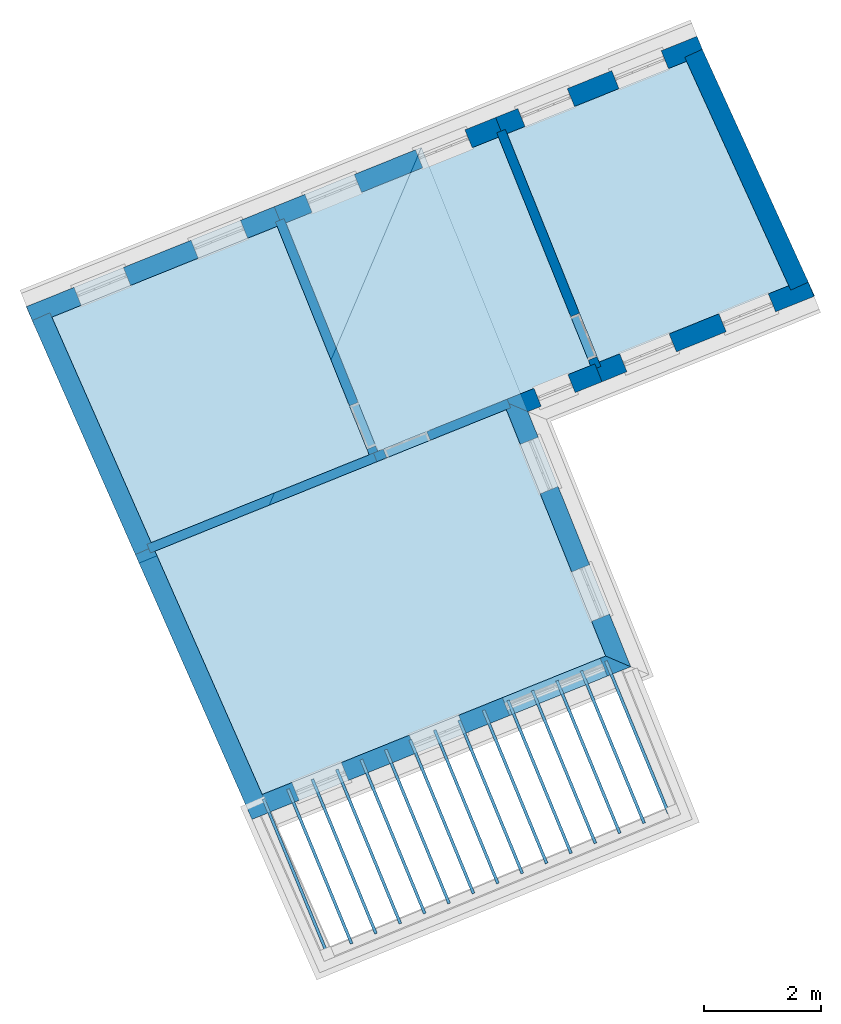
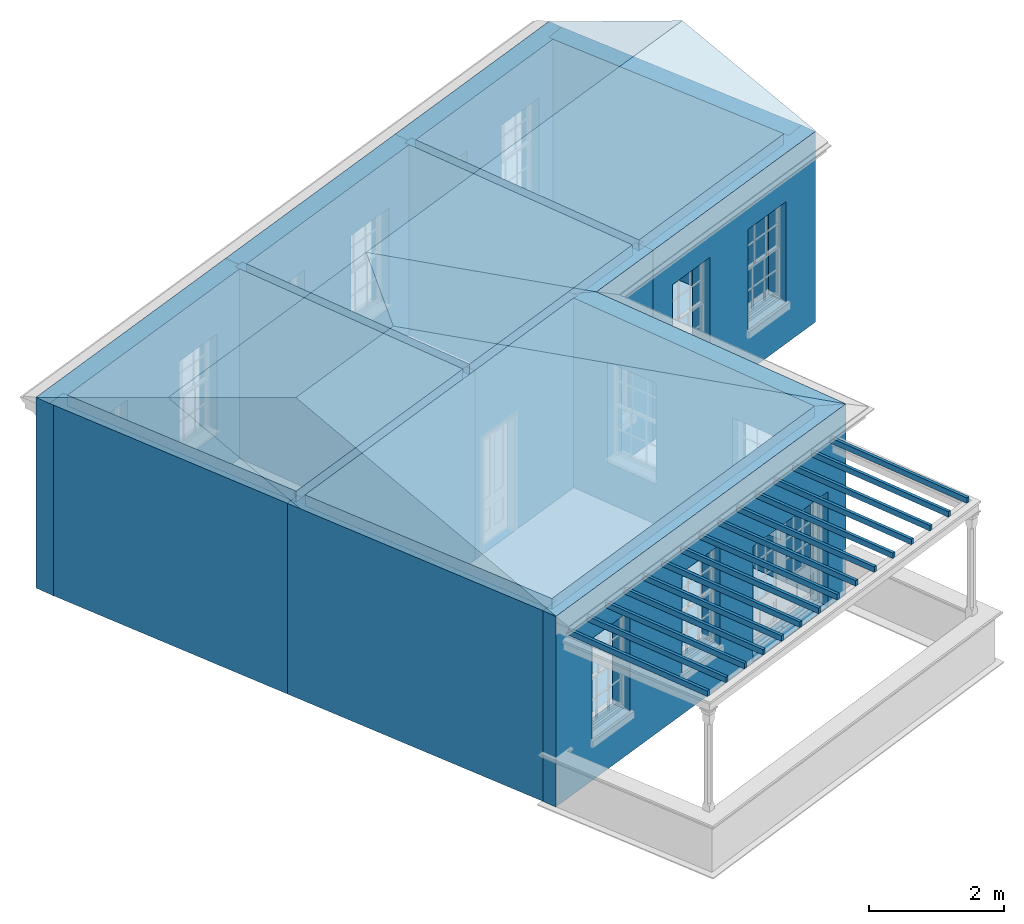
# One storey, part 1 of 11: 22 slabs, 14 walls, 2 roofs, 17 openings.
"""IFC2X3 building model written with IfcOpenShell, lengths in metres."""

from ifc_helpers import new_model, si_unit, frame, origin, place, context, subcontext, project, spatial, polyline, outline, extrude, faceted_brep, material, layer, layer_set, layer_usage, element, save


model = new_model("IFC2X3")

# Units and contexts
model_context = context("Model", 3, world=origin())
body_context = subcontext(model_context, "Body", "Model", "MODEL_VIEW")
ifc_project = project(units=[si_unit("PLANEANGLEUNIT", "RADIAN"), si_unit("MASSUNIT", "GRAM", prefix="KILO"), si_unit("FORCEUNIT", "NEWTON", prefix="KILO"), si_unit("LENGTHUNIT", "METRE")], contexts=[model_context])

# Site, building, storey
site_placement = place(None, origin())
site = spatial("IfcSite", under=ifc_project, at=site_placement, CompositionType="ELEMENT")
building_placement = place(None, origin())
building = spatial("IfcBuilding", under=site, at=building_placement, Name="Building plot-6", CompositionType="ELEMENT")
storey_placement = place(None, frame((0.0, 0.0, 7.6)))
storey = spatial("IfcBuildingStorey", under=building, at=storey_placement, Name="Floor 1", CompositionType="ELEMENT", Elevation=7.6)

# Slabs
slab_1_placement = place(storey_placement, frame((0.0, 0.0, 3.25)))
element("IfcSlab", 1, at=slab_1_placement, inside=storey, Name="Slab", ObjectType="Slab", PredefinedType="FLOOR", context=body_context, shape_type="SweptSolid", body=[
    extrude(outline(polyline([(76.2577457902025, 64.6686020443732), (74.5135630710952, 68.4972584544611), (71.4513008288675, 67.2630875650073), (73.0224536163486, 63.3646956170308), (76.2577457902025, 64.6686020443732)])), origin(), (0.0, 0.0, 1.0), 0.2),
])
slab_2_placement = place(storey_placement, frame((0.0, 0.0, 3.25)))
element("IfcSlab", 2, at=slab_2_placement, inside=storey, Name="Slab", ObjectType="Slab", PredefinedType="FLOOR", context=body_context, shape_type="SweptSolid", body=[
    extrude(outline(polyline([(63.6804234192607, 64.1312229741175), (65.3761845528931, 60.2830514126522), (69.0963028168147, 61.7823552943856), (67.5251500293337, 65.6807472423621), (63.6804234192607, 64.1312229741175)])), origin(), (0.0, 0.0, 1.0), 0.2),
])
slab_3_placement = place(storey_placement, frame((0.0, 0.0, 3.25)))
element("IfcSlab", 3, at=slab_3_placement, inside=storey, Name="Slab", ObjectType="Slab", PredefinedType="FLOOR", context=body_context, shape_type="SweptSolid", body=[
    extrude(outline(polyline([(65.440737456539, 60.1365622385029), (67.2704046682872, 55.9845191284493), (73.1321758860389, 58.3469645447258), (71.4369567405552, 62.553193703002), (65.440737456539, 60.1365622385029)])), origin(), (0.0, 0.0, 1.0), 0.2),
])
slab_4_placement = place(storey_placement, frame((0.0, 0.0, 2.95)))
element("IfcSlab", 4, at=slab_4_placement, inside=storey, Name="Slab", ObjectType="Slab", PredefinedType="FLOOR", context=body_context, shape_type="SweptSolid", body=[
    extrude(outline(polyline([(68.3583884275437, 53.2552034661946), (68.4046173515025, 53.2742530485946), (67.3157256834263, 55.9167409029541), (67.2694967594675, 55.897691320554), (68.3583884275437, 53.2552034661946)])), origin(), (0.0, 0.0, 1.0), 0.1),
])
slab_5_placement = place(storey_placement, frame((0.0, 0.0, 2.95)))
element("IfcSlab", 5, at=slab_5_placement, inside=storey, Name="Slab", ObjectType="Slab", PredefinedType="FLOOR", context=body_context, shape_type="SweptSolid", body=[
    extrude(outline(polyline([(68.7744487431724, 53.4266497077952), (68.8206776671311, 53.4456992901953), (67.7331158388372, 56.0849599314387), (67.6868869148785, 56.0659103490387), (68.7744487431724, 53.4266497077952)])), origin(), (0.0, 0.0, 1.0), 0.1),
])
slab_6_placement = place(storey_placement, frame((0.0, 0.0, 2.95)))
element("IfcSlab", 6, at=slab_6_placement, inside=storey, Name="Slab", ObjectType="Slab", PredefinedType="FLOOR", context=body_context, shape_type="SweptSolid", body=[
    extrude(outline(polyline([(69.190509058801, 53.5980959493958), (69.2367379827598, 53.6171455317959), (68.1505059942482, 56.2531789599234), (68.1042770702895, 56.2341293775233), (69.190509058801, 53.5980959493958)])), origin(), (0.0, 0.0, 1.0), 0.1),
])
slab_7_placement = place(storey_placement, frame((0.0, 0.0, 2.95)))
element("IfcSlab", 7, at=slab_7_placement, inside=storey, Name="Slab", ObjectType="Slab", PredefinedType="FLOOR", context=body_context, shape_type="SweptSolid", body=[
    extrude(outline(polyline([(69.6065693744297, 53.7695421909965), (69.6527982983884, 53.7885917733965), (68.5678961496592, 56.4213979884081), (68.5216672257005, 56.402348406008), (69.6065693744297, 53.7695421909965)])), origin(), (0.0, 0.0, 1.0), 0.1),
])
slab_8_placement = place(storey_placement, frame((0.0, 0.0, 2.95)))
element("IfcSlab", 8, at=slab_8_placement, inside=storey, Name="Slab", ObjectType="Slab", PredefinedType="FLOOR", context=body_context, shape_type="SweptSolid", body=[
    extrude(outline(polyline([(70.0226296900584, 53.9409884325971), (70.0688586140171, 53.9600380149972), (68.9852863050702, 56.5896170168928), (68.9390573811115, 56.5705674344927), (70.0226296900584, 53.9409884325971)])), origin(), (0.0, 0.0, 1.0), 0.1),
])
slab_9_placement = place(storey_placement, frame((0.0, 0.0, 2.95)))
element("IfcSlab", 9, at=slab_9_placement, inside=storey, Name="Slab", ObjectType="Slab", PredefinedType="FLOOR", context=body_context, shape_type="SweptSolid", body=[
    extrude(outline(polyline([(70.438690005687, 54.1124346741977), (70.4849189296458, 54.1314842565978), (69.4026764604812, 56.7578360453775), (69.3564475365225, 56.7387864629774), (70.438690005687, 54.1124346741977)])), origin(), (0.0, 0.0, 1.0), 0.1),
])
slab_10_placement = place(storey_placement, frame((0.0, 0.0, 2.95)))
element("IfcSlab", 10, at=slab_10_placement, inside=storey, Name="Slab", ObjectType="Slab", PredefinedType="FLOOR", context=body_context, shape_type="SweptSolid", body=[
    extrude(outline(polyline([(70.8547503213157, 54.2838809157983), (70.9009792452744, 54.3029304981984), (69.8200666158922, 56.9260550738621), (69.7738376919335, 56.9070054914621), (70.8547503213157, 54.2838809157983)])), origin(), (0.0, 0.0, 1.0), 0.1),
])
slab_11_placement = place(storey_placement, frame((0.0, 0.0, 2.95)))
element("IfcSlab", 11, at=slab_11_placement, inside=storey, Name="Slab", ObjectType="Slab", PredefinedType="FLOOR", context=body_context, shape_type="SweptSolid", body=[
    extrude(outline(polyline([(71.2708106369443, 54.455327157399), (71.3170395609031, 54.474376739799), (70.2374567713032, 57.0942741023468), (70.1912278473444, 57.0752245199468), (71.2708106369443, 54.455327157399)])), origin(), (0.0, 0.0, 1.0), 0.1),
])
slab_12_placement = place(storey_placement, frame((0.0, 0.0, 2.95)))
element("IfcSlab", 12, at=slab_12_placement, inside=storey, Name="Slab", ObjectType="Slab", PredefinedType="FLOOR", context=body_context, shape_type="SweptSolid", body=[
    extrude(outline(polyline([(71.686870952573, 54.6267733989996), (71.7330998765318, 54.6458229813997), (70.6548469267142, 57.2624931308315), (70.6086180027554, 57.2434435484314), (71.686870952573, 54.6267733989996)])), origin(), (0.0, 0.0, 1.0), 0.1),
])
slab_13_placement = place(storey_placement, frame((0.0, 0.0, 2.95)))
element("IfcSlab", 13, at=slab_13_placement, inside=storey, Name="Slab", ObjectType="Slab", PredefinedType="FLOOR", context=body_context, shape_type="SweptSolid", body=[
    extrude(outline(polyline([(72.1029312682017, 54.7982196406002), (72.1491601921604, 54.8172692230003), (71.0722370821252, 57.4307121593162), (71.0260081581664, 57.4116625769161), (72.1029312682017, 54.7982196406002)])), origin(), (0.0, 0.0, 1.0), 0.1),
])
slab_14_placement = place(storey_placement, frame((0.0, 0.0, 2.95)))
element("IfcSlab", 14, at=slab_14_placement, inside=storey, Name="Slab", ObjectType="Slab", PredefinedType="FLOOR", context=body_context, shape_type="SweptSolid", body=[
    extrude(outline(polyline([(72.5189915838303, 54.9696658822008), (72.5652205077891, 54.9887154646009), (71.4896272375362, 57.5989311878009), (71.4433983135774, 57.5798816054008), (72.5189915838303, 54.9696658822008)])), origin(), (0.0, 0.0, 1.0), 0.1),
])
slab_15_placement = place(storey_placement, frame((0.0, 0.0, 2.95)))
element("IfcSlab", 15, at=slab_15_placement, inside=storey, Name="Slab", ObjectType="Slab", PredefinedType="FLOOR", context=body_context, shape_type="SweptSolid", body=[
    extrude(outline(polyline([(72.935051899459, 55.1411121238014), (72.9812808234177, 55.1601617062015), (71.9070173929472, 57.7671502162856), (71.8607884689884, 57.7481006338855), (72.935051899459, 55.1411121238014)])), origin(), (0.0, 0.0, 1.0), 0.1),
])
slab_16_placement = place(storey_placement, frame((0.0, 0.0, 2.95)))
element("IfcSlab", 16, at=slab_16_placement, inside=storey, Name="Slab", ObjectType="Slab", PredefinedType="FLOOR", context=body_context, shape_type="SweptSolid", body=[
    extrude(outline(polyline([(73.3511122150876, 55.3125583654021), (73.3973411390464, 55.3316079478022), (72.3244075483582, 57.9353692447702), (72.2781786243994, 57.9163196623702), (73.3511122150876, 55.3125583654021)])), origin(), (0.0, 0.0, 1.0), 0.1),
])
slab_17_placement = place(storey_placement, frame((0.0, 0.0, 2.95)))
element("IfcSlab", 17, at=slab_17_placement, inside=storey, Name="Slab", ObjectType="Slab", PredefinedType="FLOOR", context=body_context, shape_type="SweptSolid", body=[
    extrude(outline(polyline([(73.7671725307163, 55.4840046070027), (73.8134014546751, 55.5030541894028), (72.7417977037691, 58.1035882732549), (72.6955687798104, 58.0845386908549), (73.7671725307163, 55.4840046070027)])), origin(), (0.0, 0.0, 1.0), 0.1),
])
slab_18_placement = place(storey_placement, frame((0.0, 0.0, 2.95)))
element("IfcSlab", 18, at=slab_18_placement, inside=storey, Name="Slab", ObjectType="Slab", PredefinedType="FLOOR", context=body_context, shape_type="SweptSolid", body=[
    extrude(outline(polyline([(74.183232846345, 55.6554508486033), (74.2294617703037, 55.6745004310034), (73.1591878591801, 58.2718073017396), (73.1129589352214, 58.2527577193395), (74.183232846345, 55.6554508486033)])), origin(), (0.0, 0.0, 1.0), 0.1),
])
slab_19_placement = place(storey_placement, frame((0.0, 0.0, 3.25)))
element("IfcSlab", 19, at=slab_19_placement, inside=storey, Name="Slab", ObjectType="Slab", PredefinedType="FLOOR", context=body_context, shape_type="SweptSolid", body=[
    extrude(outline(polyline([(69.2447037412141, 61.842164705329), (72.8740526919492, 63.3048862060874), (71.3028999044681, 67.2032781540639), (67.6735509537331, 65.7405566533055), (69.2447037412141, 61.842164705329)])), origin(), (0.0, 0.0, 1.0), 0.2),
])
slab_20_placement = place(storey_placement, origin())
element("IfcSlab", 20, at=slab_20_placement, inside=storey, Name="Slab", ObjectType="Slab", PredefinedType="FLOOR", context=body_context, shape_type="SweptSolid", body=[
    extrude(outline(polyline([(76.2577457902025, 64.6686020443732), (74.5135630710952, 68.4972584544611), (71.4513008288675, 67.2630875650073), (73.0224536163486, 63.3646956170308), (76.2577457902025, 64.6686020443732)])), origin(), (0.0, 0.0, 1.0), 0.02),
])
slab_21_placement = place(storey_placement, origin())
element("IfcSlab", 21, at=slab_21_placement, inside=storey, Name="Slab", ObjectType="Slab", PredefinedType="FLOOR", context=body_context, shape_type="SweptSolid", body=[
    extrude(outline(polyline([(63.6804234192607, 64.1312229741175), (65.3761845528931, 60.2830514126522), (69.0963028168147, 61.7823552943856), (67.5251500293337, 65.6807472423621), (63.6804234192607, 64.1312229741175)])), origin(), (0.0, 0.0, 1.0), 0.02),
])
slab_22_placement = place(storey_placement, origin())
element("IfcSlab", 22, at=slab_22_placement, inside=storey, Name="Slab", ObjectType="Slab", PredefinedType="FLOOR", context=body_context, shape_type="SweptSolid", body=[
    extrude(outline(polyline([(65.440737456539, 60.1365622385029), (67.2704046682872, 55.9845191284493), (73.1321758860389, 58.3469645447258), (71.4369567405552, 62.553193703002), (65.440737456539, 60.1365622385029)])), origin(), (0.0, 0.0, 1.0), 0.02),
])

# Wall, openings
ifc_material_1 = material(Name="Masonry")
ifc_layer_1 = layer(ifc_material_1, 0.33, ventilated=False)
ifc_layer_set_1 = layer_set([ifc_layer_1], Name="My Wall")
ifc_layer_usage_1 = layer_usage(ifc_layer_set_1, "AXIS2", "NEGATIVE", 0.08)
wall_1_placement = place(storey_placement, origin())
wall_1 = element("IfcWallStandardCase", 23, at=wall_1_placement, inside=storey, material=ifc_layer_usage_1, Name="exterior", context=body_context, shape_type="SweptSolid", body=[
    extrude(outline(polyline([(74.8164196462422, 68.6193174876725), (74.6930627361715, 68.9253943942464), (71.253743456597, 67.5392597661094), (71.3771003666678, 67.2331828595356), (74.8164196462422, 68.6193174876725)])), origin(), (0.0, 0.0, 1.0), 3.45),
])
opening_1_placement = place(storey_placement, frame((0.0, 0.0, 0.75)))
element("IfcOpeningElement", 24, at=opening_1_placement, cuts=wall_1, Name="Opening", ObjectType="Opening", context=body_context, shape_type="SweptSolid", body=[
    extrude(outline(polyline([(74.0813407117581, 68.6788545961331), (73.2373104542364, 68.3386885713926), (73.3606673643071, 68.0326116648188), (74.2046976218289, 68.3727776895593), (74.0813407117581, 68.6788545961331)])), origin(), (0.0, 0.0, 1.0), 1.82),
])
opening_2_placement = place(storey_placement, frame((0.0, 0.0, 0.75)))
element("IfcOpeningElement", 25, at=opening_2_placement, cuts=wall_1, Name="Opening", ObjectType="Opening", context=body_context, shape_type="SweptSolid", body=[
    extrude(outline(polyline([(72.477619294158, 68.0325133843641), (71.6335890366363, 67.6923473596236), (71.756945946707, 67.3862704530498), (72.6009762042287, 67.7264364777903), (72.477619294158, 68.0325133843641)])), origin(), (0.0, 0.0, 1.0), 1.82),
])

wall_2_placement = place(storey_placement, origin())
wall_2 = element("IfcWallStandardCase", 26, at=wall_2_placement, inside=storey, material=ifc_layer_usage_1, Name="exterior", context=body_context, shape_type="SweptSolid", body=[
    extrude(outline(polyline([(71.3771003666678, 67.2331828595356), (71.253743456597, 67.5392597661094), (67.4759935814627, 66.0167288544076), (67.5993504915334, 65.7106519478338), (71.3771003666678, 67.2331828595356)])), origin(), (0.0, 0.0, 1.0), 3.45),
])
opening_3_placement = place(storey_placement, frame((0.0, 0.0, 0.75)))
element("IfcOpeningElement", 27, at=opening_3_placement, cuts=wall_2, Name="Opening", ObjectType="Opening", context=body_context, shape_type="SweptSolid", body=[
    extrude(outline(polyline([(70.7313211165743, 67.3287100505542), (69.8872908590526, 66.9885440258137), (70.0106477691233, 66.6824671192399), (70.8546780266451, 67.0226331439804), (70.7313211165743, 67.3287100505542)])), origin(), (0.0, 0.0, 1.0), 1.82),
])
opening_4_placement = place(storey_placement, frame((0.0, 0.0, 0.75)))
element("IfcOpeningElement", 28, at=opening_4_placement, cuts=wall_2, Name="Opening", ObjectType="Opening", context=body_context, shape_type="SweptSolid", body=[
    extrude(outline(polyline([(68.8424461790071, 66.5674445947033), (67.9984159214854, 66.2272785699628), (68.1217728315561, 65.921201663389), (68.9658030890779, 66.2613676881295), (68.8424461790071, 66.5674445947033)])), origin(), (0.0, 0.0, 1.0), 1.82),
])

wall_3_placement = place(storey_placement, origin())
wall_3 = element("IfcWallStandardCase", 29, at=wall_3_placement, inside=storey, material=ifc_layer_usage_1, Name="exterior", context=body_context, shape_type="SweptSolid", body=[
    extrude(outline(polyline([(67.5993504915334, 65.7106519478338), (67.4759935814627, 66.0167288544076), (63.2485799606473, 64.3129718225815), (63.3719368707181, 64.0068949160076), (67.5993504915334, 65.7106519478338)])), origin(), (0.0, 0.0, 1.0), 3.45),
])
opening_5_placement = place(storey_placement, frame((0.0, 0.0, 0.75)))
element("IfcOpeningElement", 30, at=opening_5_placement, cuts=wall_3, Name="Opening", ObjectType="Opening", context=body_context, shape_type="SweptSolid", body=[
    extrude(outline(polyline([(66.8991244161132, 65.7842356599711), (66.0550941585915, 65.4440696352306), (66.1784510686622, 65.1379927286567), (67.022481326184, 65.4781587533973), (66.8991244161132, 65.7842356599711)])), origin(), (0.0, 0.0, 1.0), 1.82),
])
opening_6_placement = place(storey_placement, frame((0.0, 0.0, 0.75)))
element("IfcOpeningElement", 31, at=opening_6_placement, cuts=wall_3, Name="Opening", ObjectType="Opening", context=body_context, shape_type="SweptSolid", body=[
    extrude(outline(polyline([(64.9013558278926, 64.9790832463575), (64.0573255703709, 64.638917221617), (64.1806824804416, 64.3328403150432), (65.0247127379634, 64.6730063397837), (64.9013558278926, 64.9790832463575)])), origin(), (0.0, 0.0, 1.0), 1.82),
])

wall_4_placement = place(storey_placement, origin())
wall_4 = element("IfcWallStandardCase", 32, at=wall_4_placement, inside=storey, material=ifc_layer_usage_1, Name="exterior", context=body_context, shape_type="SweptSolid", body=[
    extrude(outline(polyline([(66.9666616124471, 55.8621028205896), (67.0900185225178, 55.5560259140157), (73.5616097026835, 58.1642445482227), (73.1321758860389, 58.3469645447258), (66.9666616124471, 55.8621028205896)])), origin(), (0.0, 0.0, 1.0), 3.45),
])
opening_7_placement = place(storey_placement, frame((0.0, 0.0, 0.75)))
element("IfcOpeningElement", 33, at=opening_7_placement, cuts=wall_4, Name="Opening", ObjectType="Opening", context=body_context, shape_type="SweptSolid", body=[
    extrude(outline(polyline([(67.9007863622407, 55.8827863240463), (68.7448166197625, 56.2229523487868), (68.6214597096917, 56.5290292553606), (67.77742945217, 56.1888632306201), (67.9007863622407, 55.8827863240463)])), origin(), (0.0, 0.0, 1.0), 1.82),
])
opening_8_placement = place(storey_placement, frame((0.0, 0.0, 0.75)))
element("IfcOpeningElement", 34, at=opening_8_placement, cuts=wall_4, Name="Opening", ObjectType="Opening", context=body_context, shape_type="SweptSolid", body=[
    extrude(outline(polyline([(69.9033991260465, 56.6898910657159), (70.7474293835683, 57.0300570904565), (70.6240724734975, 57.3361339970303), (69.7800422159758, 56.9959679722898), (69.9033991260465, 56.6898910657159)])), origin(), (0.0, 0.0, 1.0), 1.82),
])
opening_9_placement = place(storey_placement, frame((0.0, 0.0, 0.0199999999999996)))
element("IfcOpeningElement", 35, at=opening_9_placement, cuts=wall_4, Name="Opening", ObjectType="Opening", context=body_context, shape_type="SweptSolid", body=[
    extrude(outline(polyline([(71.4932718188664, 57.3306508831993), (73.16278221836, 58.0035067563124), (73.0394253082893, 58.3095836628862), (71.3699149087957, 57.6367277897731), (71.4932718188664, 57.3306508831993)])), origin(), (0.0, 0.0, 1.0), 2.08),
])

wall_5_placement = place(storey_placement, origin())
wall_5 = element("IfcWallStandardCase", 36, at=wall_5_placement, inside=storey, material=ifc_layer_usage_1, Name="exterior", context=body_context, shape_type="SweptSolid", body=[
    extrude(outline(polyline([(73.1321758860389, 58.3469645447258), (73.5616097026835, 58.1642445482227), (71.8065811462563, 62.5188746308983), (71.3771473296118, 62.7015946274014), (73.1321758860389, 58.3469645447258)])), origin(), (0.0, 0.0, 1.0), 3.45),
])
opening_10_placement = place(storey_placement, frame((0.0, 0.0, 0.75)))
element("IfcOpeningElement", 37, at=opening_10_placement, cuts=wall_5, Name="Opening", ObjectType="Opening", context=body_context, shape_type="SweptSolid", body=[
    extrude(outline(polyline([(73.1994833713479, 59.0627633845049), (72.8593173466074, 59.9067936420266), (72.5532404400336, 59.7834367319559), (72.8934064647741, 58.9394064744341), (73.1994833713479, 59.0627633845049)])), origin(), (0.0, 0.0, 1.0), 1.82),
])
opening_11_placement = place(storey_placement, frame((0.0, 0.0, 0.75)))
element("IfcOpeningElement", 38, at=opening_11_placement, cuts=wall_5, Name="Opening", ObjectType="Opening", context=body_context, shape_type="SweptSolid", body=[
    extrude(outline(polyline([(72.3219690931343, 61.2400784258427), (71.9818030683938, 62.0841086833644), (71.67572616182, 61.9607517732937), (72.0158921865605, 61.1167215157719), (72.3219690931343, 61.2400784258427)])), origin(), (0.0, 0.0, 1.0), 1.82),
])

# Wall, opening
wall_6_placement = place(storey_placement, origin())
wall_6 = element("IfcWallStandardCase", 39, at=wall_6_placement, inside=storey, material=ifc_layer_usage_1, Name="exterior", context=body_context, shape_type="SweptSolid", body=[
    extrude(outline(polyline([(71.3771473296118, 62.7015946274014), (71.8065811462563, 62.5188746308983), (73.0716100642196, 63.0287140049853), (72.9482531541489, 63.3347909115591), (71.3771473296118, 62.7015946274014)])), origin(), (0.0, 0.0, 1.0), 3.45),
])
opening_12_placement = place(storey_placement, frame((0.0, 0.0, 0.75)))
element("IfcOpeningElement", 40, at=opening_12_placement, cuts=wall_6, Name="Opening", ObjectType="Opening", context=body_context, shape_type="SweptSolid", body=[
    extrude(outline(polyline([(72.0333118275833, 62.6102529598935), (72.6130029385186, 62.8438834713911), (72.4896460284478, 63.1499603779649), (71.9099549175126, 62.9163298664673), (72.0333118275833, 62.6102529598935)])), origin(), (0.0, 0.0, 1.0), 1.82),
])

# Wall, openings
wall_7_placement = place(storey_placement, origin())
wall_7 = element("IfcWallStandardCase", 41, at=wall_7_placement, inside=storey, material=ifc_layer_usage_1, Name="exterior", context=body_context, shape_type="SweptSolid", body=[
    extrude(outline(polyline([(72.9482531541489, 63.3347909115591), (73.0716100642196, 63.0287140049853), (76.6905460430273, 64.487238808724), (76.5671891329565, 64.7933157152979), (72.9482531541489, 63.3347909115591)])), origin(), (0.0, 0.0, 1.0), 3.45),
])
opening_13_placement = place(storey_placement, frame((0.0, 0.0, 0.75)))
element("IfcOpeningElement", 42, at=opening_13_placement, cuts=wall_7, Name="Opening", ObjectType="Opening", context=body_context, shape_type="SweptSolid", body=[
    extrude(outline(polyline([(73.4963598190671, 63.1998991423999), (74.3403900765889, 63.5400651671405), (74.2170331665181, 63.8461420737143), (73.3730029089964, 63.5059760489738), (73.4963598190671, 63.1998991423999)])), origin(), (0.0, 0.0, 1.0), 1.82),
])
opening_14_placement = place(storey_placement, frame((0.0, 0.0, 0.75)))
element("IfcOpeningElement", 43, at=opening_14_placement, cuts=wall_7, Name="Opening", ObjectType="Opening", context=body_context, shape_type="SweptSolid", body=[
    extrude(outline(polyline([(75.1898895862839, 63.8824354419698), (76.0339198438056, 64.2226014667103), (75.9105629337349, 64.5286783732842), (75.0665326762132, 64.1885123485436), (75.1898895862839, 63.8824354419698)])), origin(), (0.0, 0.0, 1.0), 1.82),
])

# Walls
wall_8_placement = place(storey_placement, origin())
element("IfcWallStandardCase", 44, at=wall_8_placement, inside=storey, material=ifc_layer_usage_1, Name="party", context=body_context, shape_type="SweptSolid", body=[
    extrude(outline(polyline([(76.2924159257401, 64.5924976115003), (76.5927219825354, 64.7293050391205), (74.7821430848777, 68.7037077358946), (74.4818370280824, 68.5669003082744), (76.2924159257401, 64.5924976115003)])), origin(), (0.0, 0.0, 1.0), 3.45),
])
wall_9_placement = place(storey_placement, origin())
element("IfcWallStandardCase", 45, at=wall_9_placement, inside=storey, material=ifc_layer_usage_1, Name="party", context=body_context, shape_type="SweptSolid", body=[
    extrude(outline(polyline([(63.6471158083565, 64.2068075588329), (63.3451361135705, 64.0737351577237), (65.1054501508488, 60.0790744221091), (65.4074298456348, 60.2121468232183), (63.6471158083565, 64.2068075588329)])), origin(), (0.0, 0.0, 1.0), 3.45),
])
wall_10_placement = place(storey_placement, origin())
element("IfcWallStandardCase", 46, at=wall_10_placement, inside=storey, material=ifc_layer_usage_1, Name="party", context=body_context, shape_type="SweptSolid", body=[
    extrude(outline(polyline([(65.4074298456348, 60.2121468232183), (65.1054501508488, 60.0790744221091), (66.9996702662429, 55.7805421379062), (67.3016499610289, 55.9136145390154), (65.4074298456348, 60.2121468232183)])), origin(), (0.0, 0.0, 1.0), 3.45),
])

# Wall, opening
ifc_material_2 = material(Name="Masonry")
ifc_layer_2 = layer(ifc_material_2, 0.16, ventilated=False)
ifc_layer_set_2 = layer_set([ifc_layer_2], Name="My Wall")
ifc_layer_usage_2 = layer_usage(ifc_layer_set_2, "AXIS2", "NEGATIVE", 0.08)
wall_11_placement = place(storey_placement, origin())
wall_11 = element("IfcWallStandardCase", 47, at=wall_11_placement, inside=storey, material=ifc_layer_usage_2, Name="interior", context=body_context, shape_type="SweptSolid", body=[
    extrude(outline(polyline([(69.1705032790144, 61.8122599998573), (69.2303126899578, 61.6638590754579), (71.5111572027549, 62.5830984084737), (71.4513477918115, 62.7314993328731), (69.1705032790144, 61.8122599998573)])), origin(), (0.0, 0.0, 1.0), 3.45),
])
opening_15_placement = place(storey_placement, frame((0.0, 0.0, 0.0199999999999996)))
element("IfcOpeningElement", 48, at=opening_15_placement, cuts=wall_11, Name="Opening", ObjectType="Opening", context=body_context, shape_type="SweptSolid", body=[
    extrude(outline(polyline([(69.3972637299072, 61.7311446627692), (70.1392683519043, 62.0301917174862), (70.0794589409609, 62.1785926418856), (69.3374543189638, 61.8795455871686), (69.3972637299072, 61.7311446627692)])), origin(), (0.0, 0.0, 1.0), 2.1),
])

wall_12_placement = place(storey_placement, origin())
wall_12 = element("IfcWallStandardCase", 49, at=wall_12_placement, inside=storey, material=ifc_layer_usage_2, Name="interior", context=body_context, shape_type="SweptSolid", body=[
    extrude(outline(polyline([(71.4213961233958, 67.337288027207), (71.2729951989964, 67.2774786162636), (72.9039573974209, 63.2306857438877), (73.0523583218203, 63.2904951548311), (71.4213961233958, 67.337288027207)])), origin(), (0.0, 0.0, 1.0), 3.45),
])
opening_16_placement = place(storey_placement, frame((0.0, 0.0, 0.0199999999999996)))
element("IfcOpeningElement", 50, at=opening_16_placement, cuts=wall_12, Name="Opening", ObjectType="Opening", context=body_context, shape_type="SweptSolid", body=[
    extrude(outline(polyline([(72.5376247553926, 64.1396414058342), (72.8366718101096, 63.3976367838371), (72.985072734509, 63.4574461947804), (72.686025679792, 64.1994508167776), (72.5376247553926, 64.1396414058342)])), origin(), (0.0, 0.0, 1.0), 2.1),
])

wall_13_placement = place(storey_placement, origin())
wall_13 = element("IfcWallStandardCase", 51, at=wall_13_placement, inside=storey, material=ifc_layer_usage_2, Name="interior", context=body_context, shape_type="SweptSolid", body=[
    extrude(outline(polyline([(69.1262075222864, 61.7081548321859), (69.2746084466858, 61.7679642431293), (67.6436462482614, 65.8147571155052), (67.495245323862, 65.7549477045618), (69.1262075222864, 61.7081548321859)])), origin(), (0.0, 0.0, 1.0), 3.45),
])
opening_17_placement = place(storey_placement, frame((0.0, 0.0, 0.0199999999999996)))
element("IfcOpeningElement", 52, at=opening_17_placement, cuts=wall_13, Name="Opening", ObjectType="Opening", context=body_context, shape_type="SweptSolid", body=[
    extrude(outline(polyline([(69.2073228593745, 61.9349152830787), (68.9082758046576, 62.6769199050758), (68.7598748802581, 62.6171104941324), (69.0589219349751, 61.8751058721353), (69.2073228593745, 61.9349152830787)])), origin(), (0.0, 0.0, 1.0), 2.1),
])

# Wall
wall_14_placement = place(storey_placement, origin())
element("IfcWallStandardCase", 53, at=wall_14_placement, inside=storey, material=ifc_layer_usage_2, Name="interior", context=body_context, shape_type="SweptSolid", body=[
    extrude(outline(polyline([(65.3043179414271, 60.2540873093915), (65.3641273523705, 60.1056863849921), (69.2303126899578, 61.6638590754579), (69.1705032790144, 61.8122599998573), (65.3043179414271, 60.2540873093915)])), origin(), (0.0, 0.0, 1.0), 3.45),
])

# Roofs
roof_1_placement = place(building_placement, origin())
element("IfcRoof", 54, at=roof_1_placement, inside=storey, Name="Roof", ShapeType="FREEFORM", context=body_context, shape_type="Brep", held_by="IfcProductRepresentation", body=[
    faceted_brep([(69.988715, 67.02942, 11.05), (63.24105, 64.309937, 11.05), (65.169181, 59.934451, 13.029544), (67.342574, 60.810385, 13.029544), (67.097312, 55.558965, 11.05), (73.56161, 58.164245, 11.05)], [[[0, 1, 2, 3]], [[4, 5, 3, 2]], [[5, 4, 1, 0]], [[5, 0, 3]], [[1, 4, 2]]]),
])
roof_2_placement = place(building_placement, origin())
element("IfcRoof", 55, at=roof_2_placement, inside=storey, Name="Roof", ShapeType="FREEFORM", context=body_context, shape_type="Brep", held_by="IfcProductRepresentation", body=[
    faceted_brep([(65.203092, 59.857498, 11.05), (76.701066, 64.491479, 11.05), (75.692033, 66.706409, 12.057179), (64.222071, 62.083717, 12.057179), (74.682999, 68.921339, 11.05), (63.24105, 64.309937, 11.05)], [[[0, 1, 2, 3]], [[4, 5, 3, 2]], [[5, 4, 1, 0]], [[5, 0, 3]], [[1, 4, 2]]]),
])

save(model, "model.ifc")
